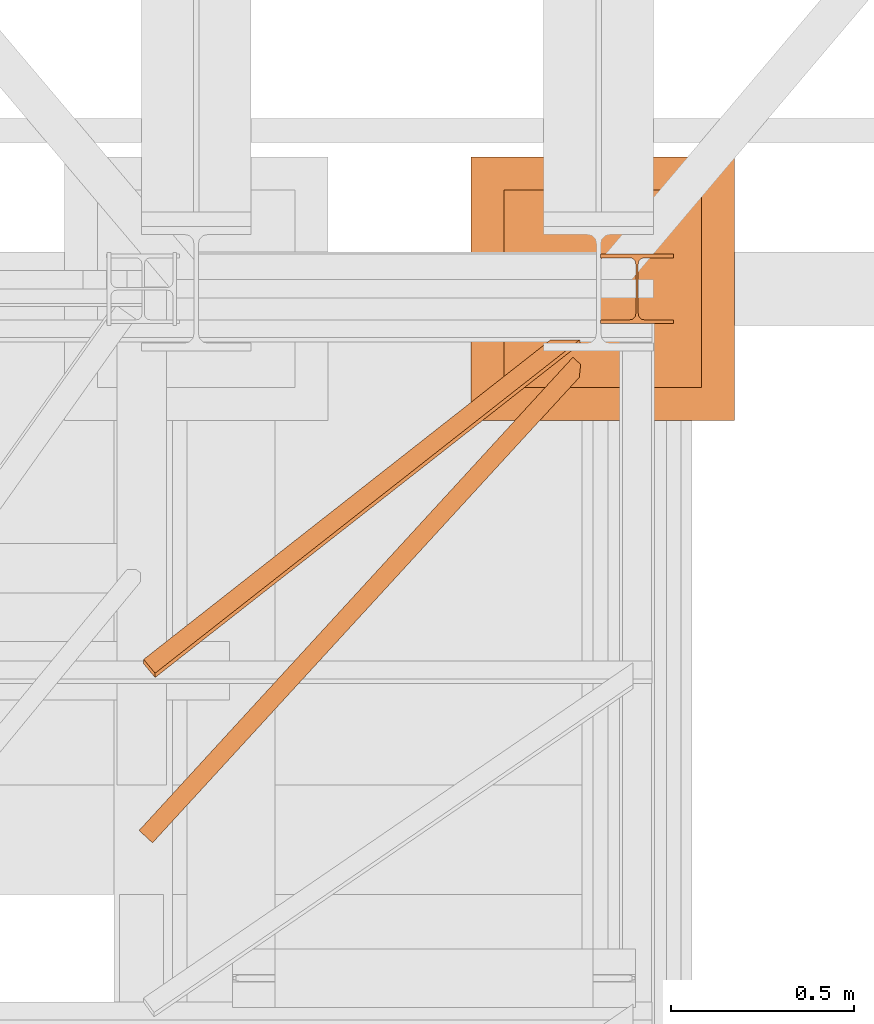
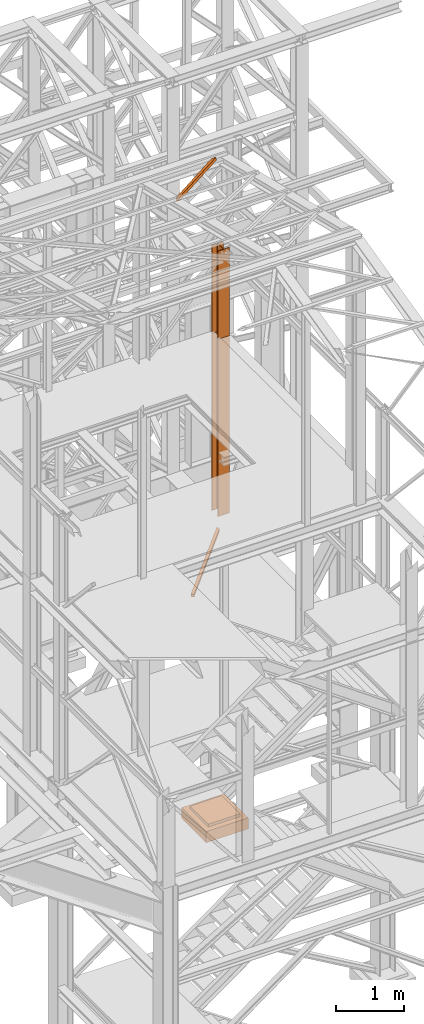
# One storey, part 79 of 208: 5 proxies.
"""IFC2X3 building model written with IfcOpenShell, lengths in millimetres."""

from ifc_helpers import new_model, entity, si_unit, converted_unit, frame, origin, origin_with_axes, place, context, subcontext, project, spatial, faceted_brep, element, save


model = new_model("IFC2X3")

# Units and contexts
model_context = context("Model", 3, precision=1e-05, world=origin())
plan_context = context("Plan", 3, precision=1e-05, world=origin())
body_context = subcontext(model_context, "Body", "Model", "MODEL_VIEW")
ifc_project = project(units=[si_unit("LENGTHUNIT", "METRE", prefix="MILLI"), converted_unit("PLANEANGLEUNIT", "DEGREE", entity("IfcPlaneAngleMeasure", 0.0174532925199433), si_unit("PLANEANGLEUNIT", "RADIAN"), dimensions=[0, 0, 0, 0, 0, 0, 0]), si_unit("AREAUNIT", "SQUARE_METRE"), si_unit("VOLUMEUNIT", "CUBIC_METRE")], contexts=[model_context, plan_context])

# Building, storey
building_placement = place(None, origin())
building = spatial("IfcBuilding", under=ifc_project, at=building_placement, CompositionType="COMPLEX")
storey_placement = place(building_placement, origin_with_axes())
storey = spatial("IfcBuildingStorey", under=building, at=storey_placement, Name="Geschoss", CompositionType="ELEMENT")

# Proxies
proxy_1_placement = place(storey_placement, frame((6244.358622037166, -17622.57439531565, -315.01), z_axis=(0.0, 0.0, 1.0), x_axis=(1.0, 0.0, 0.0)))
element("IfcBuildingElementProxy", 1, at=proxy_1_placement, inside=storey, context=body_context, shape_type="Brep", body=[
    faceted_brep([(630.0100000000002, 630.0099999999984, 250.01), (630.0100000000002, 90.0099999999984, 250.01), (90.01000000000022, 90.0099999999984, 250.01), (90.01000000000022, 630.0099999999984, 250.01), (630.0100000000002, 630.0099999999984, 200.01), (630.0100000000002, 90.0099999999984, 200.01), (630.0100000000002, 90.0099999999984, 250.01), (630.0100000000002, 630.0099999999984, 250.01), (90.01000000000022, 630.0099999999984, 200.01), (630.0100000000002, 630.0099999999984, 200.01), (630.0100000000002, 630.0099999999984, 250.01), (90.01000000000022, 630.0099999999984, 250.01), (90.01000000000022, 90.0099999999984, 200.01), (90.01000000000022, 630.0099999999984, 200.01), (90.01000000000022, 630.0099999999984, 250.01), (90.01000000000022, 90.0099999999984, 250.01), (630.0100000000002, 90.0099999999984, 200.01), (90.01000000000022, 90.0099999999984, 200.01), (90.01000000000022, 90.0099999999984, 250.01), (630.0100000000002, 90.0099999999984, 250.01), (720.0100000000002, 0.00999999999839929, 0.009999999999990905), (720.0100000000002, 720.0099999999984, 0.009999999999990905), (0.01000000000021828, 720.0099999999984, 0.009999999999990905), (0.01000000000021828, 0.00999999999839929, 0.009999999999990905), (720.0100000000002, 720.0099999999984, 200.01), (720.0100000000002, 0.00999999999839929, 200.01), (0.01000000000021828, 0.00999999999839929, 200.01), (0.01000000000021828, 720.0099999999984, 200.01), (90.01000000000022, 90.0099999999984, 200.01), (630.0100000000002, 90.0099999999984, 200.01), (630.0100000000002, 630.0099999999984, 200.01), (90.01000000000022, 630.0099999999984, 200.01), (720.0100000000002, 720.0099999999984, 0.009999999999990905), (720.0100000000002, 0.00999999999839929, 0.009999999999990905), (720.0100000000002, 0.00999999999839929, 200.01), (720.0100000000002, 720.0099999999984, 200.01), (0.01000000000021828, 720.0099999999984, 0.009999999999990905), (720.0100000000002, 720.0099999999984, 0.009999999999990905), (720.0100000000002, 720.0099999999984, 200.01), (0.01000000000021828, 720.0099999999984, 200.01), (0.01000000000021828, 0.00999999999839929, 0.009999999999990905), (0.01000000000021828, 720.0099999999984, 0.009999999999990905), (0.01000000000021828, 720.0099999999984, 200.01), (0.01000000000021828, 0.00999999999839929, 200.01), (720.0100000000002, 0.00999999999839929, 0.009999999999990905), (0.01000000000021828, 0.00999999999839929, 0.009999999999990905), (0.01000000000021828, 0.00999999999839929, 200.01), (720.0100000000002, 0.00999999999839929, 200.01)], [[[0, 1, 2, 3]], [[4, 5, 6, 7]], [[8, 9, 10, 11]], [[12, 13, 14, 15]], [[16, 17, 18, 19]], [[20, 21, 22, 23]], [[24, 25, 26, 27], [28, 29, 30, 31]], [[32, 33, 34, 35]], [[36, 37, 38, 39]], [[40, 41, 42, 43]], [[44, 45, 46, 47]]], orient=[[False], [False], [False], [False], [False], [False], [False, False], [False], [False], [False], [False]]),
])
proxy_2_placement = place(storey_placement, frame((6598.254967038541, -17357.57439657638, 8484.990002086155), z_axis=(0.0, 0.0, 1.0), x_axis=(1.0, 0.0, 0.0)))
element("IfcBuildingElementProxy", 2, at=proxy_2_placement, inside=storey, context=body_context, shape_type="Brep", body=[
    faceted_brep([(0.01000000000021828, 190.0100211771169, 1592.269667156872), (200.0100029802325, 190.0100211771169, 1592.269667156872), (200.0100029802325, 180.0100232632794, 1592.269667156872), (121.2600035762789, 180.0100158126988, 1592.269667156872), (111.9441915473344, 178.1454707654157, 1592.269667156872), (105.1245498640838, 171.3258276851811, 1592.269667156872), (103.2600015571716, 162.0100165875592, 1592.269667156872), (103.2600015571716, 28.01000579911852, 1592.269667156872), (105.1245498640838, 18.6941947014966, 1592.269667156872), (111.9441915473344, 11.87455162126207, 1592.269667156872), (121.2600035762789, 10.0100065739789, 1592.269667156872), (200.0100029802325, 10.0100065739789, 1592.269667156872), (200.0100029802325, 0.01000866014146595, 1592.269667156872), (0.01000000000021828, 0.01000866014146595, 1592.269667156872), (0.01000000000021828, 10.0100065739789, 1592.269667156872), (78.75999940395377, 10.0100065739789, 1592.269667156872), (88.07581143289826, 11.87455162126207, 1592.269667156872), (94.89545311614893, 18.6941947014966, 1592.269667156872), (96.76000142306111, 28.01000579911852, 1592.269667156872), (96.76000142306111, 162.0100165875592, 1592.269667156872), (94.89545311614893, 171.3258276851811, 1592.269667156872), (88.07581143289826, 178.1454707654157, 1592.269667156872), (78.75999940395377, 180.0100158126988, 1592.269667156872), (0.01000000000021828, 180.0100232632794, 1592.269667156872), (200.0100029802325, 190.0100211771169, 1592.269667156872), (0.01000000000021828, 190.0100211771169, 1592.269667156872), (0.01000000000021828, 190.0100125169774, 0.01000000000021828), (200.0100029802325, 190.0100125169774, 0.01000000000021828), (200.0100029802325, 180.0100232632794, 1592.269667156872), (200.0100029802325, 190.0100211771169, 1592.269667156872), (200.0100029802325, 190.0100125169774, 0.01000000000021828), (200.0100029802325, 180.01001460314, 0.01000000000021828), (121.2600035762789, 180.0100158126988, 1592.269667156872), (200.0100029802325, 180.0100232632794, 1592.269667156872), (200.0100029802325, 180.01001460314, 0.01000000000021828), (121.2600035762789, 180.0100071525594, 0.01000000000021828), (111.9441915473344, 178.1454707654157, 1592.269667156872), (121.2600035762789, 180.0100158126988, 1592.269667156872), (121.2600035762789, 180.0100071525594, 0.01000000000021828), (111.9441915473344, 178.1454621052762, 0.01000000000021828), (105.1245498640838, 171.3258276851811, 1592.269667156872), (111.9441915473344, 178.1454707654157, 1592.269667156872), (111.9441915473344, 178.1454621052762, 0.01000000000021828), (105.1245498640838, 171.3258190250417, 0.01000000000021828), (103.2600015571716, 162.0100165875592, 1592.269667156872), (105.1245498640838, 171.3258276851811, 1592.269667156872), (105.1245498640838, 171.3258190250417, 0.01000000000021828), (103.2600015571716, 162.0100079274198, 0.01000000000021828), (103.2600015571716, 28.01000579911852, 1592.269667156872), (103.2600015571716, 162.0100165875592, 1592.269667156872), (103.2600015571716, 162.0100079274198, 0.01000000000021828), (103.2600015571716, 28.00999713897909, 0.01000000000021828), (105.1245498640838, 18.6941947014966, 1592.269667156872), (103.2600015571716, 28.01000579911852, 1592.269667156872), (103.2600015571716, 28.00999713897909, 0.01000000000021828), (105.1245498640838, 18.69418604135717, 0.01000000000021828), (111.9441915473344, 11.87455162126207, 1592.269667156872), (105.1245498640838, 18.6941947014966, 1592.269667156872), (105.1245498640838, 18.69418604135717, 0.01000000000021828), (111.9441915473344, 11.87454296112264, 0.01000000000021828), (121.2600035762789, 10.0100065739789, 1592.269667156872), (111.9441915473344, 11.87455162126207, 1592.269667156872), (111.9441915473344, 11.87454296112264, 0.01000000000021828), (121.2600035762789, 10.00999791383947, 0.01000000000021828), (200.0100029802325, 10.0100065739789, 1592.269667156872), (121.2600035762789, 10.0100065739789, 1592.269667156872), (121.2600035762789, 10.00999791383947, 0.01000000000021828), (200.0100029802325, 10.00999791383947, 0.01000000000021828), (200.0100029802325, 0.01000866014146595, 1592.269667156872), (200.0100029802325, 10.0100065739789, 1592.269667156872), (200.0100029802325, 10.00999791383947, 0.01000000000021828), (200.0100029802325, 0.01000000000203727, 0.01000000000021828), (0.01000000000021828, 0.01000866014146595, 1592.269667156872), (200.0100029802325, 0.01000866014146595, 1592.269667156872), (200.0100029802325, 0.01000000000203727, 0.01000000000021828), (0.01000000000021828, 0.01000000000203727, 0.01000000000021828), (0.01000000000021828, 10.0100065739789, 1592.269667156872), (0.01000000000021828, 0.01000866014146595, 1592.269667156872), (0.01000000000021828, 0.01000000000203727, 0.01000000000021828), (0.01000000000021828, 10.00999791383947, 0.01000000000021828), (78.75999940395377, 10.0100065739789, 1592.269667156872), (0.01000000000021828, 10.0100065739789, 1592.269667156872), (0.01000000000021828, 10.00999791383947, 0.01000000000021828), (78.75999940395377, 10.00999791383947, 0.01000000000021828), (88.07581143289826, 11.87455162126207, 1592.269667156872), (78.75999940395377, 10.0100065739789, 1592.269667156872), (78.75999940395377, 10.00999791383947, 0.01000000000021828), (88.07581143289826, 11.87454296112264, 0.01000000000021828), (94.89545311614893, 18.6941947014966, 1592.269667156872), (88.07581143289826, 11.87455162126207, 1592.269667156872), (88.07581143289826, 11.87454296112264, 0.01000000000021828), (94.89545311614893, 18.69418604135717, 0.01000000000021828), (96.76000142306111, 28.01000579911852, 1592.269667156872), (94.89545311614893, 18.6941947014966, 1592.269667156872), (94.89545311614893, 18.69418604135717, 0.01000000000021828), (96.76000142306111, 28.00999713897909, 0.01000000000021828), (96.76000142306111, 162.0100165875592, 1592.269667156872), (96.76000142306111, 28.01000579911852, 1592.269667156872), (96.76000142306111, 28.00999713897909, 0.01000000000021828), (96.76000142306111, 162.0100079274198, 0.01000000000021828), (94.89545311614893, 171.3258276851811, 1592.269667156872), (96.76000142306111, 162.0100165875592, 1592.269667156872), (96.76000142306111, 162.0100079274198, 0.01000000000021828), (94.89545311614893, 171.3258190250417, 0.01000000000021828), (88.07581143289826, 178.1454707654157, 1592.269667156872), (94.89545311614893, 171.3258276851811, 1592.269667156872), (94.89545311614893, 171.3258190250417, 0.01000000000021828), (88.07581143289826, 178.1454621052762, 0.01000000000021828), (78.75999940395377, 180.0100158126988, 1592.269667156872), (88.07581143289826, 178.1454707654157, 1592.269667156872), (88.07581143289826, 178.1454621052762, 0.01000000000021828), (78.75999940395377, 180.0100071525594, 0.01000000000021828), (0.01000000000021828, 180.0100232632794, 1592.269667156872), (78.75999940395377, 180.0100158126988, 1592.269667156872), (78.75999940395377, 180.0100071525594, 0.01000000000021828), (0.01000000000021828, 180.01001460314, 0.01000000000021828), (0.01000000000021828, 190.0100211771169, 1592.269667156872), (0.01000000000021828, 180.0100232632794, 1592.269667156872), (0.01000000000021828, 180.01001460314, 0.01000000000021828), (0.01000000000021828, 190.0100125169774, 0.01000000000021828), (0.01000000000021828, 190.0100125169774, 0.01000000000021828), (0.01000000000021828, 180.01001460314, 0.01000000000021828), (78.75999940395377, 180.0100071525594, 0.01000000000021828), (88.07581143289826, 178.1454621052762, 0.01000000000021828), (94.89545311614893, 171.3258190250417, 0.01000000000021828), (96.76000142306111, 162.0100079274198, 0.01000000000021828), (96.76000142306111, 28.00999713897909, 0.01000000000021828), (94.89545311614893, 18.69418604135717, 0.01000000000021828), (88.07581143289826, 11.87454296112264, 0.01000000000021828), (78.75999940395377, 10.00999791383947, 0.01000000000021828), (0.01000000000021828, 10.00999791383947, 0.01000000000021828), (0.01000000000021828, 0.01000000000203727, 0.01000000000021828), (200.0100029802325, 0.01000000000203727, 0.01000000000021828), (200.0100029802325, 10.00999791383947, 0.01000000000021828), (121.2600035762789, 10.00999791383947, 0.01000000000021828), (111.9441915473344, 11.87454296112264, 0.01000000000021828), (105.1245498640838, 18.69418604135717, 0.01000000000021828), (103.2600015571716, 28.00999713897909, 0.01000000000021828), (103.2600015571716, 162.0100079274198, 0.01000000000021828), (105.1245498640838, 171.3258190250417, 0.01000000000021828), (111.9441915473344, 178.1454621052762, 0.01000000000021828), (121.2600035762789, 180.0100071525594, 0.01000000000021828), (200.0100029802325, 180.01001460314, 0.01000000000021828), (200.0100029802325, 190.0100125169774, 0.01000000000021828)], [[[0, 1, 2, 3, 4, 5, 6, 7, 8, 9, 10, 11, 12, 13, 14, 15, 16, 17, 18, 19, 20, 21, 22, 23]], [[24, 25, 26, 27]], [[28, 29, 30, 31]], [[32, 33, 34, 35]], [[36, 37, 38, 39]], [[40, 41, 42, 43]], [[44, 45, 46, 47]], [[48, 49, 50, 51]], [[52, 53, 54, 55]], [[56, 57, 58, 59]], [[60, 61, 62, 63]], [[64, 65, 66, 67]], [[68, 69, 70, 71]], [[72, 73, 74, 75]], [[76, 77, 78, 79]], [[80, 81, 82, 83]], [[84, 85, 86, 87]], [[88, 89, 90, 91]], [[92, 93, 94, 95]], [[96, 97, 98, 99]], [[100, 101, 102, 103]], [[104, 105, 106, 107]], [[108, 109, 110, 111]], [[112, 113, 114, 115]], [[116, 117, 118, 119]], [[120, 121, 122, 123, 124, 125, 126, 127, 128, 129, 130, 131, 132, 133, 134, 135, 136, 137, 138, 139, 140, 141, 142, 143]]], orient=[[False], [False], [False], [False], [False], [False], [False], [False], [False], [False], [False], [False], [False], [False], [False], [False], [False], [False], [False], [False], [False], [False], [False], [False], [False], [False]]),
])
proxy_3_placement = place(storey_placement, frame((5337.09535292986, -18776.90824509442, 5124.989999999998), z_axis=(0.0, 0.0, 1.0), x_axis=(1.0, 0.0, 0.0)))
element("IfcBuildingElementProxy", 3, at=proxy_3_placement, inside=storey, context=body_context, shape_type="Brep", body=[
    faceted_brep([(36.78497454417538, 0.00999999999839929, 50.01000000000022), (1203.356083073373, 1272.332118070597, 50.01000000000022), (1203.356083073372, 1272.332118070597, 0.01000000000021828), (36.78497454417538, 0.00999999999839929, 0.01000000000021828), (36.78497454417538, 0.00999999999839929, 0.01000000000021828), (1203.356083073372, 1272.332118070597, 0.01000000000021828), (1207.063078652963, 1307.646067268277, 0.01000000000021828), (1185.831632996663, 1327.203988443423, 0.01000000000021828), (0.01000000000021828, 33.88626377384571, 0.01000000000021828), (0.01000000000021828, 33.88626377384571, 0.01000000000021828), (1185.831632996663, 1327.203988443423, 0.01000000000021828), (1185.831632996663, 1327.203988443423, 50.01000000000022), (0.01000000000021828, 33.88626377384571, 50.01000000000022), (0.01000000000021828, 33.88626377384571, 50.01000000000022), (1185.831632996663, 1327.203988443423, 50.01000000000022), (1207.063078652963, 1307.646067268277, 50.01000000000022), (1203.356083073373, 1272.332118070597, 50.01000000000022), (36.78497454417538, 0.00999999999839929, 50.01000000000022), (36.78497454417538, 0.00999999999839929, 50.01000000000022), (36.78497454417538, 0.00999999999839929, 0.01000000000021828), (0.01000000000021828, 33.88626377384571, 0.01000000000021828), (0.01000000000021828, 33.88626377384571, 50.01000000000022), (33.84297658064133, 2.720101101906039, 4.010000000000218), (33.84297658064133, 2.720101101906039, 46.01000000000022), (2.951997963534268, 31.17616267193807, 46.01000000000022), (2.951997963534268, 31.17616267193807, 4.010000000000218), (1207.063078652963, 1307.646067268277, 50.01000000000022), (1185.831632996663, 1327.203988443423, 50.01000000000022), (1185.831632996663, 1327.203988443423, 0.01000000000021828), (1207.063078652963, 1307.646067268277, 0.01000000000021828), (1207.063078652963, 1307.646067268277, 4.010000000000218), (1188.773630960196, 1324.493887341516, 4.010000000000218), (1188.773630960196, 1324.493887341516, 46.01000000000022), (1207.063078652963, 1307.646067268277, 46.01000000000022), (33.84297658064133, 2.720101101906039, 46.01000000000022), (33.84297658064133, 2.720101101906039, 4.010000000000218), (1204.057723834917, 1279.016157928814, 4.010000000000218), (1204.057723834917, 1279.016157928814, 46.01000000000022), (33.84297658064133, 2.720101101906039, 4.010000000000218), (2.951997963534268, 31.17616267193807, 4.010000000000218), (1188.773630960196, 1324.493887341516, 4.010000000000218), (1207.063078652963, 1307.646067268277, 4.010000000000218), (1204.057723834917, 1279.016157928814, 4.010000000000218), (2.951997963534268, 31.17616267193807, 4.010000000000218), (2.951997963534268, 31.17616267193807, 46.01000000000022), (1188.773630960196, 1324.493887341516, 46.01000000000022), (1188.773630960196, 1324.493887341516, 4.010000000000218), (2.951997963534268, 31.17616267193807, 46.01000000000022), (33.84297658064133, 2.720101101906039, 46.01000000000022), (1204.057723834917, 1279.016157928814, 46.01000000000022), (1207.063078652963, 1307.646067268277, 46.01000000000022), (1188.773630960196, 1324.493887341516, 46.01000000000022), (1203.356083073373, 1272.332118070597, 50.01000000000022), (1207.063078652963, 1307.646067268277, 50.01000000000022), (1207.063078652963, 1307.646067268277, 46.01000000000022), (1204.057723834917, 1279.016157928814, 46.01000000000022), (1204.057723834917, 1279.016157928814, 4.010000000000218), (1207.063078652963, 1307.646067268277, 4.010000000000218), (1207.063078652963, 1307.646067268277, 0.01000000000021828), (1203.356083073372, 1272.332118070597, 0.01000000000021828)], [[[0, 1, 2, 3]], [[4, 5, 6, 7, 8]], [[9, 10, 11, 12]], [[13, 14, 15, 16, 17]], [[18, 19, 20, 21], [22, 23, 24, 25]], [[26, 27, 28, 29, 30, 31, 32, 33]], [[34, 35, 36, 37]], [[38, 39, 40, 41, 42]], [[43, 44, 45, 46]], [[47, 48, 49, 50, 51]], [[52, 53, 54, 55, 56, 57, 58, 59]]], orient=[[False], [False], [False], [False], [False, False], [False], [False], [False], [False], [False], [False]]),
])
proxy_4_placement = place(storey_placement, frame((6598.254967038549, -17357.57438790133, 5284.990005364414), z_axis=(0.0, 0.0, 1.0), x_axis=(1.0, 0.0, 0.0)))
element("IfcBuildingElementProxy", 4, at=proxy_4_placement, inside=storey, context=body_context, shape_type="Brep", body=[
    faceted_brep([(0.01000000000021828, 190.0100125169738, 3200.009996721743), (200.0100029802325, 190.0100125169738, 3200.009996721743), (200.0100029802325, 180.0100146031364, 3200.009996721743), (121.2600035762789, 180.0100071525558, 3200.009996721743), (111.9441915473344, 178.1454621052726, 3200.009996721743), (105.1245498640838, 171.3258190250381, 3200.009996721743), (103.2600015571716, 162.0100079274162, 3200.009996721743), (103.2600015571716, 28.00999713897545, 3200.009996721743), (105.1245498640838, 18.69418604135353, 3200.009996721743), (111.9441915473344, 11.87454296111901, 3200.009996721743), (121.2600035762789, 10.00999791383583, 3200.009996721743), (200.0100029802325, 10.00999791383583, 3200.009996721743), (200.0100029802325, 0.00999999999839929, 3200.009996721743), (0.01000000000021828, 0.00999999999839929, 3200.009996721743), (0.01000000000021828, 10.00999791383583, 3200.009996721743), (78.75999940395377, 10.00999791383583, 3200.009996721743), (88.07581143289826, 11.87454296111901, 3200.009996721743), (94.89545311614893, 18.69418604135353, 3200.009996721743), (96.76000142306111, 28.00999713897545, 3200.009996721743), (96.76000142306111, 162.0100079274162, 3200.009996721743), (94.89545311614893, 171.3258190250381, 3200.009996721743), (88.07581143289826, 178.1454621052726, 3200.009996721743), (78.75999940395377, 180.0100071525558, 3200.009996721743), (0.01000000000021828, 180.0100146031364, 3200.009996721743), (200.0100029802325, 190.0100125169738, 3200.009996721743), (0.01000000000021828, 190.0100125169738, 3200.009996721743), (0.01000000000021828, 190.0100125169738, 0.01000000000021828), (200.0100029802325, 190.0100125169738, 0.01000000000021828), (200.0100029802325, 180.0100146031364, 3200.009996721743), (200.0100029802325, 190.0100125169738, 3200.009996721743), (200.0100029802325, 190.0100125169738, 0.01000000000021828), (200.0100029802325, 180.0100146031364, 0.01000000000021828), (121.2600035762789, 180.0100071525558, 3200.009996721743), (200.0100029802325, 180.0100146031364, 3200.009996721743), (200.0100029802325, 180.0100146031364, 0.01000000000021828), (121.2600035762789, 180.0100071525558, 0.01000000000021828), (111.9441915473344, 178.1454621052726, 3200.009996721743), (121.2600035762789, 180.0100071525558, 3200.009996721743), (121.2600035762789, 180.0100071525558, 0.01000000000021828), (111.9441915473344, 178.1454621052726, 0.01000000000021828), (105.1245498640838, 171.3258190250381, 3200.009996721743), (111.9441915473344, 178.1454621052726, 3200.009996721743), (111.9441915473344, 178.1454621052726, 0.01000000000021828), (105.1245498640838, 171.3258190250381, 0.01000000000021828), (103.2600015571716, 162.0100079274162, 3200.009996721743), (105.1245498640838, 171.3258190250381, 3200.009996721743), (105.1245498640838, 171.3258190250381, 0.01000000000021828), (103.2600015571716, 162.0100079274162, 0.01000000000021828), (103.2600015571716, 28.00999713897545, 3200.009996721743), (103.2600015571716, 162.0100079274162, 3200.009996721743), (103.2600015571716, 162.0100079274162, 0.01000000000021828), (103.2600015571716, 28.00999713897545, 0.01000000000021828), (105.1245498640838, 18.69418604135353, 3200.009996721743), (103.2600015571716, 28.00999713897545, 3200.009996721743), (103.2600015571716, 28.00999713897545, 0.01000000000021828), (105.1245498640838, 18.69418604135353, 0.01000000000021828), (111.9441915473344, 11.87454296111901, 3200.009996721743), (105.1245498640838, 18.69418604135353, 3200.009996721743), (105.1245498640838, 18.69418604135353, 0.01000000000021828), (111.9441915473344, 11.87454296111901, 0.01000000000021828), (121.2600035762789, 10.00999791383583, 3200.009996721743), (111.9441915473344, 11.87454296111901, 3200.009996721743), (111.9441915473344, 11.87454296111901, 0.01000000000021828), (121.2600035762789, 10.00999791383583, 0.01000000000021828), (200.0100029802325, 10.00999791383583, 3200.009996721743), (121.2600035762789, 10.00999791383583, 3200.009996721743), (121.2600035762789, 10.00999791383583, 0.01000000000021828), (200.0100029802325, 10.00999791383583, 0.01000000000021828), (200.0100029802325, 0.00999999999839929, 3200.009996721743), (200.0100029802325, 10.00999791383583, 3200.009996721743), (200.0100029802325, 10.00999791383583, 0.01000000000021828), (200.0100029802325, 0.00999999999839929, 0.01000000000021828), (0.01000000000021828, 0.00999999999839929, 3200.009996721743), (200.0100029802325, 0.00999999999839929, 3200.009996721743), (200.0100029802325, 0.00999999999839929, 0.01000000000021828), (0.01000000000021828, 0.00999999999839929, 0.01000000000021828), (0.01000000000021828, 10.00999791383583, 3200.009996721743), (0.01000000000021828, 0.00999999999839929, 3200.009996721743), (0.01000000000021828, 0.00999999999839929, 0.01000000000021828), (0.01000000000021828, 10.00999791383583, 0.01000000000021828), (78.75999940395377, 10.00999791383583, 3200.009996721743), (0.01000000000021828, 10.00999791383583, 3200.009996721743), (0.01000000000021828, 10.00999791383583, 0.01000000000021828), (78.75999940395377, 10.00999791383583, 0.01000000000021828), (88.07581143289826, 11.87454296111901, 3200.009996721743), (78.75999940395377, 10.00999791383583, 3200.009996721743), (78.75999940395377, 10.00999791383583, 0.01000000000021828), (88.07581143289826, 11.87454296111901, 0.01000000000021828), (94.89545311614893, 18.69418604135353, 3200.009996721743), (88.07581143289826, 11.87454296111901, 3200.009996721743), (88.07581143289826, 11.87454296111901, 0.01000000000021828), (94.89545311614893, 18.69418604135353, 0.01000000000021828), (96.76000142306111, 28.00999713897545, 3200.009996721743), (94.89545311614893, 18.69418604135353, 3200.009996721743), (94.89545311614893, 18.69418604135353, 0.01000000000021828), (96.76000142306111, 28.00999713897545, 0.01000000000021828), (96.76000142306111, 162.0100079274162, 3200.009996721743), (96.76000142306111, 28.00999713897545, 3200.009996721743), (96.76000142306111, 28.00999713897545, 0.01000000000021828), (96.76000142306111, 162.0100079274162, 0.01000000000021828), (94.89545311614893, 171.3258190250381, 3200.009996721743), (96.76000142306111, 162.0100079274162, 3200.009996721743), (96.76000142306111, 162.0100079274162, 0.01000000000021828), (94.89545311614893, 171.3258190250381, 0.01000000000021828), (88.07581143289826, 178.1454621052726, 3200.009996721743), (94.89545311614893, 171.3258190250381, 3200.009996721743), (94.89545311614893, 171.3258190250381, 0.01000000000021828), (88.07581143289826, 178.1454621052726, 0.01000000000021828), (78.75999940395377, 180.0100071525558, 3200.009996721743), (88.07581143289826, 178.1454621052726, 3200.009996721743), (88.07581143289826, 178.1454621052726, 0.01000000000021828), (78.75999940395377, 180.0100071525558, 0.01000000000021828), (0.01000000000021828, 180.0100146031364, 3200.009996721743), (78.75999940395377, 180.0100071525558, 3200.009996721743), (78.75999940395377, 180.0100071525558, 0.01000000000021828), (0.01000000000021828, 180.0100146031364, 0.01000000000021828), (0.01000000000021828, 190.0100125169738, 3200.009996721743), (0.01000000000021828, 180.0100146031364, 3200.009996721743), (0.01000000000021828, 180.0100146031364, 0.01000000000021828), (0.01000000000021828, 190.0100125169738, 0.01000000000021828), (0.01000000000021828, 190.0100125169738, 0.01000000000021828), (0.01000000000021828, 180.0100146031364, 0.01000000000021828), (78.75999940395377, 180.0100071525558, 0.01000000000021828), (88.07581143289826, 178.1454621052726, 0.01000000000021828), (94.89545311614893, 171.3258190250381, 0.01000000000021828), (96.76000142306111, 162.0100079274162, 0.01000000000021828), (96.76000142306111, 28.00999713897545, 0.01000000000021828), (94.89545311614893, 18.69418604135353, 0.01000000000021828), (88.07581143289826, 11.87454296111901, 0.01000000000021828), (78.75999940395377, 10.00999791383583, 0.01000000000021828), (0.01000000000021828, 10.00999791383583, 0.01000000000021828), (0.01000000000021828, 0.00999999999839929, 0.01000000000021828), (200.0100029802325, 0.00999999999839929, 0.01000000000021828), (200.0100029802325, 10.00999791383583, 0.01000000000021828), (121.2600035762789, 10.00999791383583, 0.01000000000021828), (111.9441915473344, 11.87454296111901, 0.01000000000021828), (105.1245498640838, 18.69418604135353, 0.01000000000021828), (103.2600015571716, 28.00999713897545, 0.01000000000021828), (103.2600015571716, 162.0100079274162, 0.01000000000021828), (105.1245498640838, 171.3258190250381, 0.01000000000021828), (111.9441915473344, 178.1454621052726, 0.01000000000021828), (121.2600035762789, 180.0100071525558, 0.01000000000021828), (200.0100029802325, 180.0100146031364, 0.01000000000021828), (200.0100029802325, 190.0100125169738, 0.01000000000021828)], [[[0, 1, 2, 3, 4, 5, 6, 7, 8, 9, 10, 11, 12, 13, 14, 15, 16, 17, 18, 19, 20, 21, 22, 23]], [[24, 25, 26, 27]], [[28, 29, 30, 31]], [[32, 33, 34, 35]], [[36, 37, 38, 39]], [[40, 41, 42, 43]], [[44, 45, 46, 47]], [[48, 49, 50, 51]], [[52, 53, 54, 55]], [[56, 57, 58, 59]], [[60, 61, 62, 63]], [[64, 65, 66, 67]], [[68, 69, 70, 71]], [[72, 73, 74, 75]], [[76, 77, 78, 79]], [[80, 81, 82, 83]], [[84, 85, 86, 87]], [[88, 89, 90, 91]], [[92, 93, 94, 95]], [[96, 97, 98, 99]], [[100, 101, 102, 103]], [[104, 105, 106, 107]], [[108, 109, 110, 111]], [[112, 113, 114, 115]], [[116, 117, 118, 119]], [[120, 121, 122, 123, 124, 125, 126, 127, 128, 129, 130, 131, 132, 133, 134, 135, 136, 137, 138, 139, 140, 141, 142, 143]]], orient=[[False], [False], [False], [False], [False], [False], [False], [False], [False], [False], [False], [False], [False], [False], [False], [False], [False], [False], [False], [False], [False], [False], [False], [False], [False], [False]]),
])
proxy_5_placement = place(storey_placement, frame((5349.557664480542, -18325.01341388675, 11773.47119774096), z_axis=(0.0, 0.0, 1.0), x_axis=(1.0, 0.0, 0.0)))
element("IfcBuildingElementProxy", 5, at=proxy_5_placement, inside=storey, context=body_context, shape_type="Brep", body=[
    faceted_brep([(31.43318462620846, 0.00999999999839929, 221.2188035365398), (0.01000000000021828, 37.80448812281975, 212.0449201995252), (0.01000000000021828, 49.59855381965826, 260.6340137734806), (31.43318462620846, 11.80406569683692, 269.8078971104969), (1192.128805925269, 911.3441854033154, 0.00999999999839929), (31.43318462620846, 0.00999999999839929, 221.2188035365398), (31.43318462620846, 11.80406569683692, 269.8078971104969), (1192.128805925269, 923.1382511001502, 48.59909357395554), (1112.569715090313, 911.3441854033117, 0.01000000000021828), (0.01000000000021828, 37.80448812281975, 212.0449201995252), (31.43318462620846, 0.00999999999839929, 221.2188035365398), (1192.128805925269, 911.3441854033154, 0.00999999999839929), (1112.56971509032, 923.1382511001539, 48.59909357395554), (0.01000000000021828, 49.59855381965826, 260.6340137734806), (0.01000000000021828, 37.80448812281975, 212.0449201995252), (1112.569715090313, 911.3441854033117, 0.01000000000021828), (1192.128805925269, 923.1382511001502, 48.59909357395554), (31.43318462620846, 11.80406569683692, 269.8078971104969), (0.01000000000021828, 49.59855381965826, 260.6340137734806), (1112.56971509032, 923.1382511001539, 48.59909357395554), (1192.128805925269, 911.3441854033154, 0.00999999999839929), (1192.128805925269, 923.1382511001502, 48.59909357395554), (1112.56971509032, 923.1382511001539, 48.59909357395554), (1112.569715090313, 911.3441854033117, 0.01000000000021828)], [[[0, 1, 2, 3]], [[4, 5, 6, 7]], [[8, 9, 10, 11]], [[12, 13, 14, 15]], [[16, 17, 18, 19]], [[20, 21, 22, 23]]], orient=[[False], [False], [False], [False], [False], [False]]),
])

save(model, "model.ifc")
